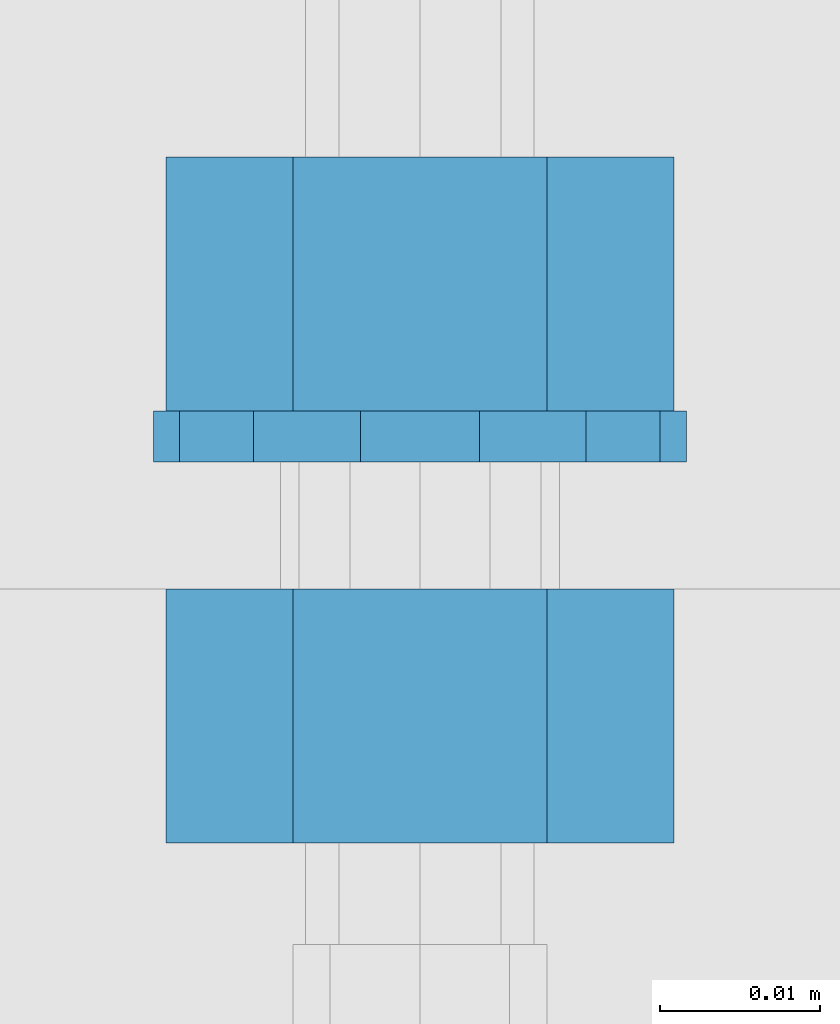
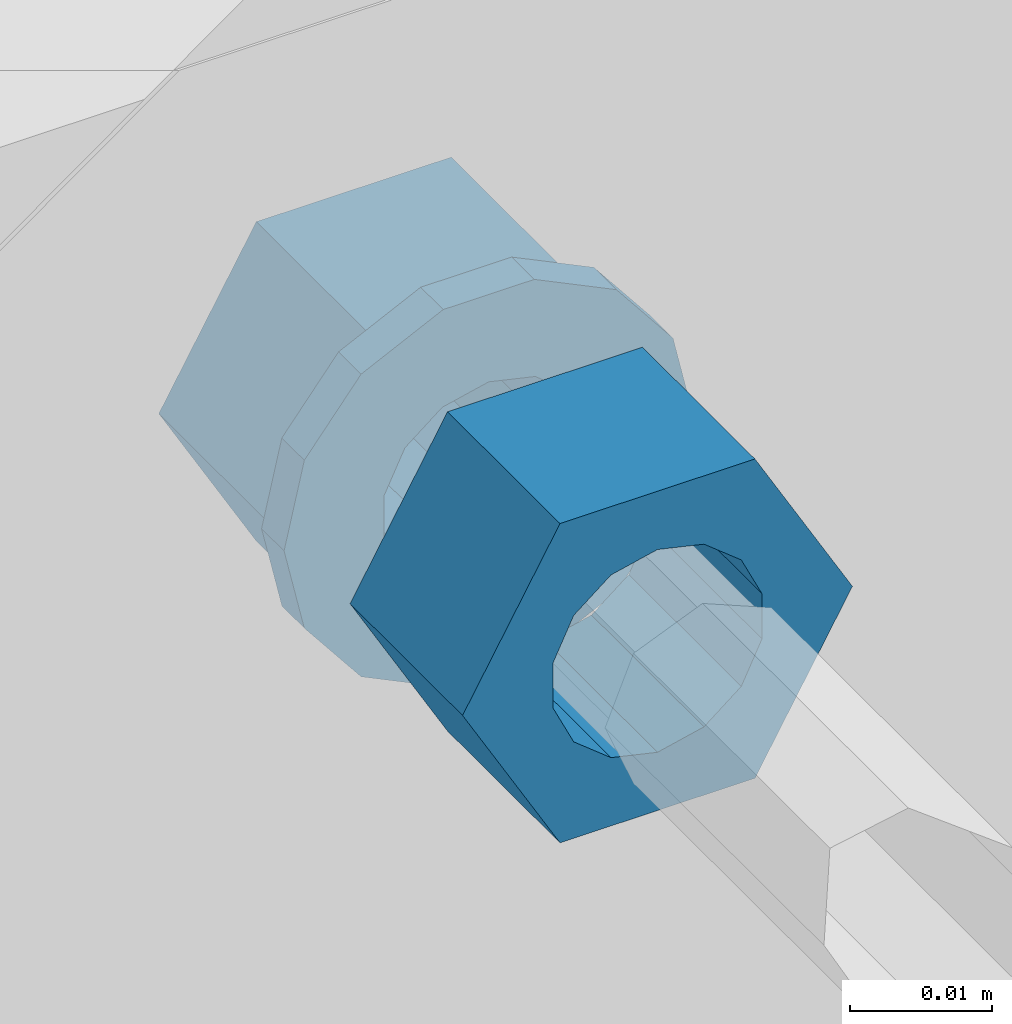
# One storey, part 637 of 975: 3 beams.
"""IFC2X3 building model written with IfcOpenShell, lengths in millimetres."""

import ifcopenshell
import ifcopenshell.guid

model = None  # the IFC model being written
_history = None  # IfcOwnerHistory: only IFC2X3 demands one
_inside = {}  # id of a spatial element -> (the spatial element, [elements in it])
_under = {}  # id of a project, library or spatial element -> (it, [spatial elements below it])
_declared = {}  # id of a project -> (the project, [libraries it declares])
_typed = {}  # id of a type object -> (the type object, [elements of that type])
_made_of = {}  # id of a material, layer set ... -> (it, [elements and type objects made of it])


def new_model(schema):
    """Start an empty IFC model of exactly this schema.

    Asked for "IFC4X3", IfcOpenShell would pick the latest addendum, in which some entities
    have other attributes; the version numbers below select the first issue.
    IFC2X3 requires an IfcOwnerHistory on every rooted entity: one is made here for all.
    """
    global model, _history
    if schema == "IFC4X3":
        model = ifcopenshell.file(schema_version=(4, 3, 0, 0))
    else:
        model = ifcopenshell.file(schema=schema)
    _inside.clear()
    _under.clear()
    _declared.clear()
    _typed.clear()
    _made_of.clear()
    _history = None
    if model.schema == "IFC2X3":
        org = make("IfcOrganization", Name="unknown")
        user = make(
            "IfcPersonAndOrganization",
            ThePerson=make("IfcPerson", FamilyName="unknown"),
            TheOrganization=org,
        )
        app = make(
            "IfcApplication",
            ApplicationDeveloper=org,
            Version="unknown",
            ApplicationFullName="unknown",
            ApplicationIdentifier="unknown",
        )
        _history = make(
            "IfcOwnerHistory",
            OwningUser=user,
            OwningApplication=app,
            ChangeAction="ADDED",
            CreationDate=0,
        )
    return model


def make(cls, **values):
    """One entity of the class cls with the attributes given. An attribute that is None is left unset."""
    return model.create_entity(
        cls, **{name: value for name, value in values.items() if value is not None}
    )


def rooted(cls, **values):
    """An entity with a GlobalId (a new one), such as an element, a storey or a relation."""
    return make(cls, GlobalId=ifcopenshell.guid.new(), OwnerHistory=_history, **values)


def si_unit(unit_type, name, prefix=None):
    """IfcSIUnit, for example si_unit("LENGTHUNIT", "METRE", prefix="MILLI")."""
    return make("IfcSIUnit", UnitType=unit_type, Prefix=prefix, Name=name)


def assignment(units):
    """IfcUnitAssignment: the units of a project."""
    return None if units is None else make("IfcUnitAssignment", Units=units)


def point(xyz):
    """IfcCartesianPoint."""
    return None if xyz is None else make("IfcCartesianPoint", Coordinates=xyz)


def direction(xyz):
    """IfcDirection."""
    return None if xyz is None else make("IfcDirection", DirectionRatios=xyz)


def frame(location, z_axis=None, x_axis=None):
    """IfcAxis2Placement3D, a coordinate frame: its origin and axes. An axis left out is left unset."""
    return make(
        "IfcAxis2Placement3D",
        Location=point(location),
        Axis=direction(z_axis),
        RefDirection=direction(x_axis),
    )


def origin_with_axes():
    """The frame at (0, 0, 0) with the z axis (0, 0, 1) and the x axis (1, 0, 0) written out."""
    return frame((0.0, 0.0, 0.0), z_axis=(0.0, 0.0, 1.0), x_axis=(1.0, 0.0, 0.0))


def place(relative_to, where):
    """IfcLocalPlacement: puts the frame where relative to a parent placement (None: the world)."""
    return make(
        "IfcLocalPlacement", PlacementRelTo=relative_to, RelativePlacement=where
    )


def context(
    kind, dimensions, precision=None, world=None, true_north=None, identifier=None
):
    """IfcGeometricRepresentationContext, for example the 3D "Model" context."""
    return make(
        "IfcGeometricRepresentationContext",
        ContextIdentifier=identifier,
        ContextType=kind,
        CoordinateSpaceDimension=dimensions,
        Precision=precision,
        WorldCoordinateSystem=world,
        TrueNorth=true_north,
    )


def subcontext(parent, identifier, kind, view, scale=None):
    """IfcGeometricRepresentationSubContext, for example "Body" below "Model"."""
    return make(
        "IfcGeometricRepresentationSubContext",
        ContextIdentifier=identifier,
        ContextType=kind,
        ParentContext=parent,
        TargetScale=scale,
        TargetView=view,
    )


def project(units=None, contexts=None):
    """IfcProject with its units and contexts."""
    return rooted(
        "IfcProject",
        Name="project",
        RepresentationContexts=contexts,
        UnitsInContext=assignment(units),
    )


def spatial(cls, under=None, at=None, **own):
    """A site, building, storey or space (cls), placed at a placement, below another one or the project."""
    s = rooted(cls, ObjectPlacement=at, **own)
    if under is not None:
        _under.setdefault(under.id(), (under, []))[1].append(s)
    return s


def faces_of(points, faces, orient=None, outer=None):
    """IfcFace entities. A face is a list of loops; a loop is a list of indices into points, from 0.

    orient and outer hold one flag for each loop. By default every Orientation is true, the
    first loop of a face is its IfcFaceOuterBound and the others are IfcFaceBound.
    """
    made = []
    for i, loops in enumerate(faces):
        bounds = []
        for j, loop in enumerate(loops):
            is_outer = j == 0 if outer is None else outer[i][j]
            bounds.append(
                make(
                    "IfcFaceOuterBound" if is_outer else "IfcFaceBound",
                    Bound=make("IfcPolyLoop", Polygon=[points[k] for k in loop]),
                    Orientation=True if orient is None else orient[i][j],
                )
            )
        made.append(make("IfcFace", Bounds=bounds))
    return made


def faceted_brep(points, faces, orient=None, outer=None, voids=None):
    """IfcFacetedBrep: a solid bounded by flat faces; with voids (closed shells), ...WithVoids."""
    shared = [point(p) for p in points]
    hull = make("IfcClosedShell", CfsFaces=faces_of(shared, faces, orient, outer))
    if voids is None:
        return make("IfcFacetedBrep", Outer=hull)
    return make(
        "IfcFacetedBrepWithVoids",
        Outer=hull,
        Voids=[
            make(cls, CfsFaces=faces_of(shared, fs, o, b)) for cls, fs, o, b in voids
        ],
    )


def shape(context_of_items, identifier, shape_type, items):
    """IfcShapeRepresentation: the items that make up one representation, for example the "Body"."""
    return make(
        "IfcShapeRepresentation",
        ContextOfItems=context_of_items,
        RepresentationIdentifier=identifier,
        RepresentationType=shape_type,
        Items=items,
    )


def material(Name=None, Category=None):
    """IfcMaterial."""
    return make("IfcMaterial", Name=Name, Category=Category)


def made_of(thing, what):
    """Note that an element or type object is made of a material, layer set ...; save() writes the relation."""
    if what is not None:
        _made_of.setdefault(what.id(), (what, []))[1].append(thing)
    return thing


def type_object(cls, material=None, **own):
    """A type object (cls), such as IfcWallType, which elements share."""
    return made_of(rooted(cls, **own), material)


def element(
    cls,
    number,
    at=None,
    inside=None,
    cuts=None,
    type_object=None,
    material=None,
    context=None,
    identifier="Body",
    shape_type=None,
    held_by="IfcProductDefinitionShape",
    body=None,
    shapes=None,
    **own,
):
    """One element of the class cls, such as IfcWall. Its Tag is "e" and its number.

    at: its placement. inside: the storey or other place that contains it. cuts: it is an
    opening in that element (IfcRelVoidsElement). A single representation is given by context,
    identifier, shape_type and body (its items); several are given by shapes. held_by: the class
    of the entity that holds the representations. save() writes the other relations.
    """
    e = rooted(cls, Tag="e%d" % number, ObjectPlacement=at, **own)
    if body is not None:
        shapes = [shape(context, identifier, shape_type, body)]
    if shapes is not None:
        e.Representation = make(held_by, Representations=shapes)
    if inside is not None:
        _inside.setdefault(inside.id(), (inside, []))[1].append(e)
    if cuts is not None:
        rooted(
            "IfcRelVoidsElement", RelatingBuildingElement=cuts, RelatedOpeningElement=e
        )
    if type_object is not None:
        _typed.setdefault(type_object.id(), (type_object, []))[1].append(e)
    return made_of(e, material)


def aggregate(whole, parts):
    """IfcRelAggregates: a whole, such as a stair, and the parts it consists of."""
    return rooted("IfcRelAggregates", RelatingObject=whole, RelatedObjects=parts)


def save(model, path):
    """Write the relations noted so far, then the file.

    IfcRelAggregates (storeys below a building ...), IfcRelContainedInSpatialStructure (elements
    in a storey), IfcRelDefinesByType, IfcRelAssociatesMaterial and IfcRelDeclares: one each for
    every whole, place, type object, material and project.
    """
    for whole, parts in _under.values():
        aggregate(whole, parts)
    for where, things in _inside.values():
        rooted(
            "IfcRelContainedInSpatialStructure",
            RelatedElements=things,
            RelatingStructure=where,
        )
    for kind, things in _typed.values():
        rooted("IfcRelDefinesByType", RelatedObjects=things, RelatingType=kind)
    for what, things in _made_of.values():
        rooted("IfcRelAssociatesMaterial", RelatedObjects=things, RelatingMaterial=what)
    for by, libraries in _declared.values():
        rooted("IfcRelDeclares", RelatingContext=by, RelatedDefinitions=libraries)
    model.write(path)


model = new_model("IFC2X3")

# Units and contexts
model_context = context("Model", 3, precision=1e-05, world=origin_with_axes())
body_context = subcontext(model_context, "Body", "Model", "MODEL_VIEW")
ifc_project = project(units=[si_unit("LENGTHUNIT", "METRE", prefix="MILLI"), si_unit("AREAUNIT", "SQUARE_METRE"), si_unit("VOLUMEUNIT", "CUBIC_METRE"), si_unit("MASSUNIT", "GRAM", prefix="KILO"), si_unit("TIMEUNIT", "SECOND"), si_unit("PLANEANGLEUNIT", "RADIAN"), si_unit("SOLIDANGLEUNIT", "STERADIAN"), si_unit("THERMODYNAMICTEMPERATUREUNIT", "DEGREE_CELSIUS"), si_unit("LUMINOUSINTENSITYUNIT", "LUMEN")], contexts=[model_context])

# Site, building, storey
site_placement = place(None, origin_with_axes())
site = spatial("IfcSite", under=ifc_project, at=site_placement, CompositionType="ELEMENT")
building_placement = place(site_placement, origin_with_axes())
building = spatial("IfcBuilding", under=site, at=building_placement, Name="Undefined", CompositionType="ELEMENT")
storey_placement = place(building_placement, origin_with_axes())
storey = spatial("IfcBuildingStorey", under=building, at=storey_placement, Name="Undefined", CompositionType="ELEMENT", Elevation=0.0)

# Beams
ifc_material = material(Name="STEEL/A36")
beam_type_1 = type_object("IfcBeamType", Name="5/8_HEAVY_HEX_NUT", PredefinedType="NOTDEFINED")
beam_1_placement = place(storey_placement, frame((28174.95, 304.799999999999, 3886.2), z_axis=(0.0, 0.0, 1.0), x_axis=(0.0, -1.0, 0.0)))
element("IfcBeam", 1, at=beam_1_placement, inside=storey, type_object=beam_type_1, material=ifc_material, Name="NUT", ObjectType="5/8_HEAVY_HEX_NUT", context=body_context, shape_type="Brep", body=[
    faceted_brep([(-1.09139364212751e-11, -15.8800001144436, -2.72848410531878e-12), (1.45519152283669e-11, -7.94000005722046, -13.7500000000036), (15.8750000000146, -7.94000005722137, -13.7500000000045), (15.8749999999891, -15.8800001144446, -2.72848410531878e-12), (2.91038304567337e-11, 7.94000005722319, -13.7500000000027), (15.8750000000291, 7.94000005722319, -13.7500000000027), (2.18278728425503e-11, 15.8800001144436, 9.09494701772928e-13), (15.8750000000218, 15.8800001144427, 9.09494701772928e-13), (-7.27595761418343e-12, 7.94000005722046, 13.7500000000027), (15.8749999999927, 7.94000005722046, 13.7500000000027), (-2.18278728425503e-11, -7.94000005722228, 13.7500000000009), (15.8749999999782, -7.94000005722319, 13.7500000000009), (-7.27595761418343e-12, 0.0, 8.72999954223724), (0.0, 3.78780484388062, 7.86545780435881), (15.875, 3.78780484387971, 7.86545780435881), (15.8749999999927, -9.09494701772928e-13, 8.72999954223724), (7.27595761418343e-12, 6.82538848405238, 5.44306568481716), (15.8750000000073, 6.82538848405238, 5.44306568481716), (1.09139364212751e-11, 8.51112022706275, 1.94260765157742), (15.8750000000109, 8.51112022706093, 1.94260765157651), (1.45519152283669e-11, 8.51112022706184, -1.94260765157651), (15.8750000000146, 8.51112022706184, -1.94260765157651), (2.18278728425503e-11, 6.8253884840542, -5.44306568481716), (15.8750000000218, 6.82538848405238, -5.44306568481716), (1.81898940354586e-11, 3.78780484388153, -7.86545780435881), (15.8750000000182, 3.78780484388062, -7.86545780435881), (1.81898940354586e-11, 9.09494701772928e-13, -8.72999954223997), (15.8750000000182, 9.09494701772928e-13, -8.72999954223997), (1.09139364212751e-11, -3.78780484387971, -7.86545780436063), (15.8750000000109, -3.78780484388062, -7.86545780436063), (3.63797880709171e-12, -6.82538848405238, -5.44306568481807), (15.8750000000036, -6.82538848405329, -5.44306568481807), (0.0, -8.51112022706184, -1.94260765157833), (15.875, -8.51112022706184, -1.94260765157833), (-7.27595761418343e-12, -8.51112022706184, 1.9426076515756), (15.8749999999927, -8.51112022706275, 1.9426076515756), (-1.09139364212751e-11, -6.82538848405329, 5.44306568481534), (15.8749999999927, -6.8253884840542, 5.44306568481534), (-7.27595761418343e-12, -3.78780484388062, 7.8654578043579), (15.8749999999927, -3.78780484388153, 7.8654578043579)], [[[0, 1, 2, 3]], [[1, 4, 5, 2]], [[4, 6, 7, 5]], [[6, 8, 9, 7]], [[8, 10, 11, 9]], [[10, 0, 3, 11]], [[12, 13, 14, 15]], [[13, 16, 17, 14]], [[16, 18, 19, 17]], [[18, 20, 21, 19]], [[20, 22, 23, 21]], [[22, 24, 25, 23]], [[24, 26, 27, 25]], [[26, 28, 29, 27]], [[28, 30, 31, 29]], [[30, 32, 33, 31]], [[32, 34, 35, 33]], [[34, 36, 37, 35]], [[36, 38, 39, 37]], [[38, 12, 15, 39]], [[5, 7, 9, 11, 3, 2], [17, 19, 21, 23, 25, 27, 29, 31, 33, 35, 37, 39, 15, 14]], [[10, 8, 6, 4, 1, 0], [38, 36, 34, 32, 30, 28, 26, 24, 22, 20, 18, 16, 13, 12]]]),
])
beam_2_placement = place(storey_placement, frame((28174.95, 331.787499999998, 3886.2), z_axis=(0.0, 0.0, 1.0), x_axis=(0.0, -1.0, 0.0)))
element("IfcBeam", 2, at=beam_2_placement, inside=storey, type_object=beam_type_1, material=ifc_material, Name="NUT", ObjectType="5/8_HEAVY_HEX_NUT", context=body_context, shape_type="Brep", body=[
    faceted_brep([(-1.09139364212751e-11, -15.8800001144436, -2.72848410531878e-12), (1.45519152283669e-11, -7.94000005722046, -13.7500000000036), (15.8750000000146, -7.94000005722137, -13.7500000000045), (15.8749999999891, -15.8800001144446, -2.72848410531878e-12), (2.91038304567337e-11, 7.94000005722319, -13.7500000000027), (15.8750000000291, 7.94000005722319, -13.7500000000027), (2.18278728425503e-11, 15.8800001144436, 9.09494701772928e-13), (15.8750000000218, 15.8800001144427, 9.09494701772928e-13), (-7.27595761418343e-12, 7.94000005722046, 13.7500000000027), (15.8749999999927, 7.94000005722046, 13.7500000000027), (-2.18278728425503e-11, -7.94000005722228, 13.7500000000009), (15.8749999999782, -7.94000005722319, 13.7500000000009), (-7.27595761418343e-12, 0.0, 8.72999954223724), (0.0, 3.78780484388062, 7.86545780435881), (15.875, 3.78780484387971, 7.86545780435881), (15.8749999999927, -9.09494701772928e-13, 8.72999954223724), (7.27595761418343e-12, 6.82538848405238, 5.44306568481716), (15.8750000000073, 6.82538848405238, 5.44306568481716), (1.09139364212751e-11, 8.51112022706275, 1.94260765157742), (15.8750000000109, 8.51112022706093, 1.94260765157651), (1.45519152283669e-11, 8.51112022706184, -1.94260765157651), (15.8750000000146, 8.51112022706184, -1.94260765157651), (2.18278728425503e-11, 6.8253884840542, -5.44306568481716), (15.8750000000218, 6.82538848405238, -5.44306568481716), (1.81898940354586e-11, 3.78780484388153, -7.86545780435881), (15.8750000000182, 3.78780484388062, -7.86545780435881), (1.81898940354586e-11, 9.09494701772928e-13, -8.72999954223997), (15.8750000000182, 9.09494701772928e-13, -8.72999954223997), (1.09139364212751e-11, -3.78780484387971, -7.86545780436063), (15.8750000000109, -3.78780484388062, -7.86545780436063), (3.63797880709171e-12, -6.82538848405238, -5.44306568481807), (15.8750000000036, -6.82538848405329, -5.44306568481807), (0.0, -8.51112022706184, -1.94260765157833), (15.875, -8.51112022706184, -1.94260765157833), (-7.27595761418343e-12, -8.51112022706184, 1.9426076515756), (15.8749999999927, -8.51112022706275, 1.9426076515756), (-1.09139364212751e-11, -6.82538848405329, 5.44306568481534), (15.8749999999927, -6.8253884840542, 5.44306568481534), (-7.27595761418343e-12, -3.78780484388062, 7.8654578043579), (15.8749999999927, -3.78780484388153, 7.8654578043579)], [[[0, 1, 2, 3]], [[1, 4, 5, 2]], [[4, 6, 7, 5]], [[6, 8, 9, 7]], [[8, 10, 11, 9]], [[10, 0, 3, 11]], [[12, 13, 14, 15]], [[13, 16, 17, 14]], [[16, 18, 19, 17]], [[18, 20, 21, 19]], [[20, 22, 23, 21]], [[22, 24, 25, 23]], [[24, 26, 27, 25]], [[26, 28, 29, 27]], [[28, 30, 31, 29]], [[30, 32, 33, 31]], [[32, 34, 35, 33]], [[34, 36, 37, 35]], [[36, 38, 39, 37]], [[38, 12, 15, 39]], [[5, 7, 9, 11, 3, 2], [17, 19, 21, 23, 25, 27, 29, 31, 33, 35, 37, 39, 15, 14]], [[10, 8, 6, 4, 1, 0], [38, 36, 34, 32, 30, 28, 26, 24, 22, 20, 18, 16, 13, 12]]]),
])
beam_type_2 = type_object("IfcBeamType", Name="5/8_WASHER", PredefinedType="NOTDEFINED")
beam_3_placement = place(storey_placement, frame((28174.95, 315.912499999998, 3886.2), z_axis=(0.0, 0.0, 1.0), x_axis=(0.0, -1.0, 0.0)))
element("IfcBeam", 3, at=beam_3_placement, inside=storey, type_object=beam_type_2, material=ifc_material, Name="WASHER", ObjectType="5/8_WASHER", context=body_context, shape_type="Brep", body=[
    faceted_brep([(1.09139364212751e-11, -16.670000076293, -2.72848410531878e-12), (2.18278728425503e-11, -15.0191510966704, -7.23284196419536), (3.1750000000211, -15.0191510966711, -7.23284196419627), (3.17500000001019, -16.6700000762937, -1.81898940354586e-12), (2.91038304567337e-11, -10.3935750445523, -13.0331308723944), (3.17500000002838, -10.3935750445526, -13.0331308723953), (2.91038304567337e-11, -3.70942398602756, -16.2520483704566), (3.17500000002838, -3.70942398602779, -16.2520483704566), (2.5465851649642e-11, 3.70942398602961, -16.2520483704557), (3.17500000002474, 3.70942398602961, -16.2520483704566), (1.45519152283669e-11, 10.3935750445542, -13.0331308723935), (3.17500000001382, 10.3935750445537, -13.0331308723944), (0.0, 15.0191510966717, -7.23284196419354), (3.17499999999927, 15.0191510966713, -7.23284196419354), (-7.27595761418343e-12, 16.6700000762933, 0.0), (3.174999999992, 16.6700000762928, -9.09494701772928e-13), (-1.81898940354586e-11, 15.0191510966706, 7.23284196419354), (3.17499999998108, 15.0191510966704, 7.23284196419354), (-2.5465851649642e-11, 10.3935750445519, 13.0331308723926), (3.17499999997381, 10.3935750445517, 13.0331308723926), (-2.5465851649642e-11, 3.70942398602733, 16.2520483704538), (3.17499999997381, 3.7094239860271, 16.2520483704529), (-2.18278728425503e-11, -3.70942398602983, 16.2520483704529), (3.17499999997744, -3.70942398603006, 16.2520483704538), (-1.09139364212751e-11, -10.3935750445542, 13.0331308723908), (3.17499999998836, -10.3935750445544, 13.0331308723908), (0.0, -15.0191510966717, 7.23284196419172), (3.17499999999927, -15.019151096672, 7.23284196419081), (-7.27595761418343e-12, 0.0, 8.72999954223724), (0.0, 3.78780484388062, 7.86545780435881), (3.17499999998472, 3.78780484387903, 7.86545780435699), (3.17499999998836, -9.09494701772928e-13, 8.72999954223542), (7.27595761418343e-12, 6.82538848405238, 5.44306568481716), (3.17499999998836, 6.82538848405102, 5.44306568481534), (1.09139364212751e-11, 8.51112022706275, 1.94260765157742), (3.174999999992, 8.51112022705979, 1.94260765157651), (1.45519152283669e-11, 8.51112022706184, -1.94260765157651), (3.17499999999563, 8.51112022706025, -1.94260765157742), (2.18278728425503e-11, 6.8253884840542, -5.44306568481716), (3.17500000000655, 6.8253884840517, -5.44306568481807), (1.81898940354586e-11, 3.78780484388153, -7.86545780435881), (3.17500000001019, 3.78780484388017, -7.86545780435972), (1.81898940354586e-11, 9.09494701772928e-13, -8.72999954223997), (3.17500000001382, 6.82121026329696e-13, -8.72999954223997), (1.09139364212751e-11, -3.78780484387971, -7.86545780436063), (3.17500000001382, -3.78780484387994, -7.86545780436063), (3.63797880709171e-12, -6.82538848405238, -5.44306568481807), (3.17500000001019, -6.82538848405147, -5.44306568481898), (0.0, -8.51112022706184, -1.94260765157833), (3.17500000001019, -8.5111202270607, -1.94260765157924), (-7.27595761418343e-12, -8.51112022706184, 1.9426076515756), (3.17500000000291, -8.51112022706093, 1.94260765157469), (-1.09139364212751e-11, -6.82538848405329, 5.44306568481534), (3.17499999999563, -6.82538848405238, 5.44306568481534), (-7.27595761418343e-12, -3.78780484388062, 7.8654578043579), (3.174999999992, -3.78780484388085, 7.86545780435699)], [[[0, 1, 2, 3]], [[1, 4, 5, 2]], [[4, 6, 7, 5]], [[6, 8, 9, 7]], [[8, 10, 11, 9]], [[10, 12, 13, 11]], [[12, 14, 15, 13]], [[14, 16, 17, 15]], [[16, 18, 19, 17]], [[18, 20, 21, 19]], [[20, 22, 23, 21]], [[22, 24, 25, 23]], [[24, 26, 27, 25]], [[26, 0, 3, 27]], [[28, 29, 30, 31]], [[29, 32, 33, 30]], [[32, 34, 35, 33]], [[34, 36, 37, 35]], [[36, 38, 39, 37]], [[38, 40, 41, 39]], [[40, 42, 43, 41]], [[42, 44, 45, 43]], [[44, 46, 47, 45]], [[46, 48, 49, 47]], [[48, 50, 51, 49]], [[50, 52, 53, 51]], [[52, 54, 55, 53]], [[54, 28, 31, 55]], [[5, 7, 9, 11, 13, 15, 17, 19, 21, 23, 25, 27, 3, 2], [33, 35, 37, 39, 41, 43, 45, 47, 49, 51, 53, 55, 31, 30]], [[26, 24, 22, 20, 18, 16, 14, 12, 10, 8, 6, 4, 1, 0], [54, 52, 50, 48, 46, 44, 42, 40, 38, 36, 34, 32, 29, 28]]]),
])

save(model, "model.ifc")
